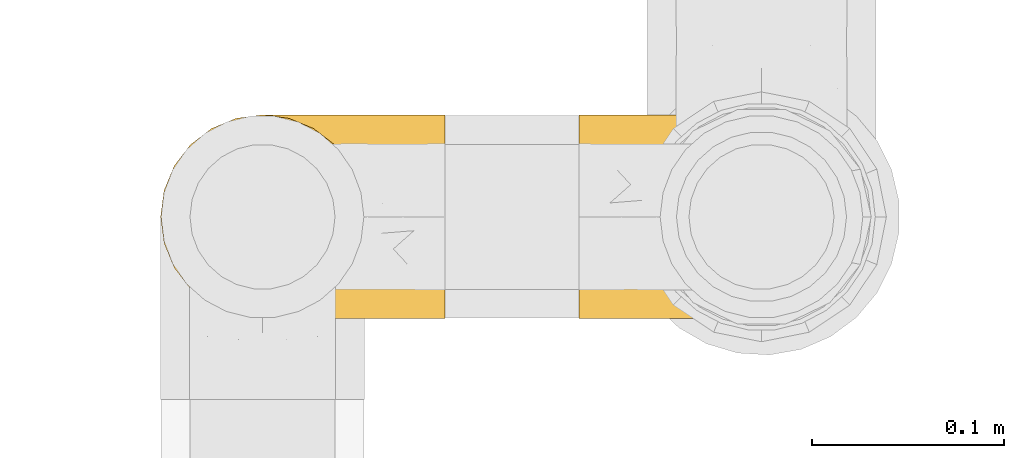
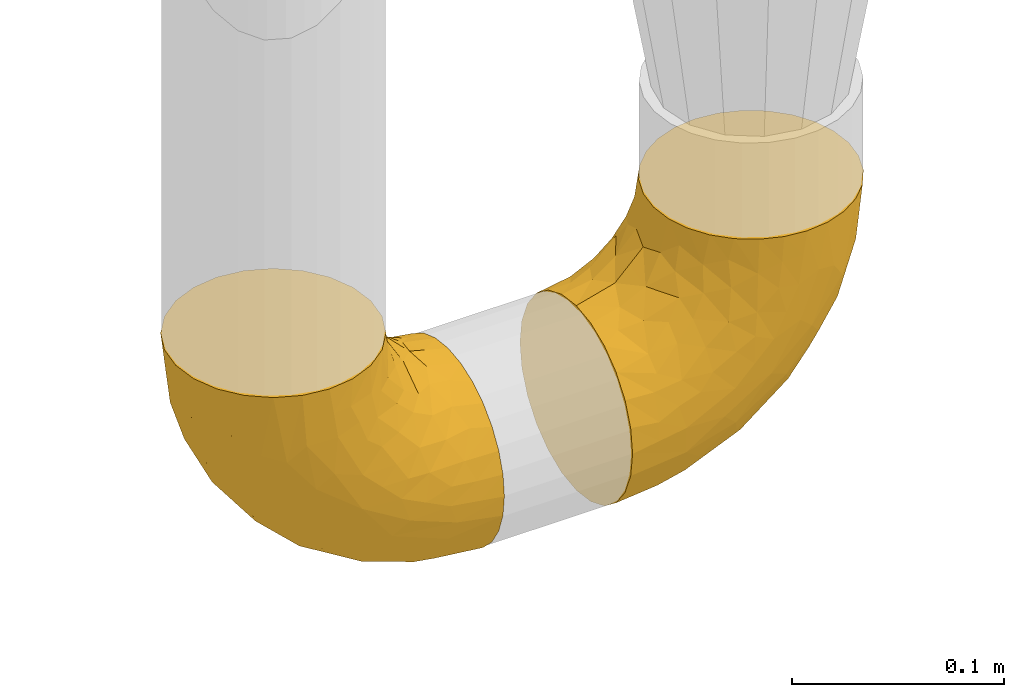
# One storey, part 476 of 827: 2 coverings.
"""IFC2X3 building model written with IfcOpenShell, lengths in millimetres."""

from ifc_helpers import new_model, entity, si_unit, converted_unit, derived_unit, direction, frame, origin, place, context, subcontext, project, spatial, faceted_brep, element, save


model = new_model("IFC2X3")

# Units and contexts
model_context = context("Model", 3, precision=0.01, world=origin(), true_north=direction((6.12303176911189e-17, 1.0)))
body_context = subcontext(model_context, "Body", "Model", "MODEL_VIEW")
ifc_project = project(units=[si_unit("LENGTHUNIT", "METRE", prefix="MILLI"), si_unit("AREAUNIT", "SQUARE_METRE"), si_unit("VOLUMEUNIT", "CUBIC_METRE"), converted_unit("PLANEANGLEUNIT", "DEGREE", entity("IfcRatioMeasure", 0.0174532925199433), si_unit("PLANEANGLEUNIT", "RADIAN"), dimensions=[0, 0, 0, 0, 0, 0, 0]), si_unit("MASSUNIT", "GRAM", prefix="KILO"), derived_unit("MASSDENSITYUNIT", [(si_unit("MASSUNIT", "GRAM", prefix="KILO"), 1), (si_unit("LENGTHUNIT", "METRE"), -3)]), derived_unit("MOMENTOFINERTIAUNIT", [(si_unit("LENGTHUNIT", "METRE"), 4)]), si_unit("TIMEUNIT", "SECOND"), si_unit("FREQUENCYUNIT", "HERTZ"), si_unit("THERMODYNAMICTEMPERATUREUNIT", "DEGREE_CELSIUS"), derived_unit("THERMALTRANSMITTANCEUNIT", [(si_unit("MASSUNIT", "GRAM", prefix="KILO"), 1), (si_unit("THERMODYNAMICTEMPERATUREUNIT", "KELVIN"), -1), (si_unit("TIMEUNIT", "SECOND"), -3)]), derived_unit("VOLUMETRICFLOWRATEUNIT", [(si_unit("LENGTHUNIT", "METRE"), 3), (si_unit("TIMEUNIT", "SECOND"), -1)]), derived_unit("MASSFLOWRATEUNIT", [(si_unit("MASSUNIT", "GRAM", prefix="KILO"), 1), (si_unit("TIMEUNIT", "SECOND"), -1)]), derived_unit("ROTATIONALFREQUENCYUNIT", [(si_unit("TIMEUNIT", "SECOND"), -1)]), si_unit("ELECTRICCURRENTUNIT", "AMPERE"), si_unit("ELECTRICVOLTAGEUNIT", "VOLT"), si_unit("POWERUNIT", "WATT"), si_unit("FORCEUNIT", "NEWTON", prefix="KILO"), si_unit("ILLUMINANCEUNIT", "LUX"), si_unit("LUMINOUSFLUXUNIT", "LUMEN"), si_unit("LUMINOUSINTENSITYUNIT", "CANDELA"), derived_unit("USERDEFINED", [(si_unit("MASSUNIT", "GRAM", prefix="KILO"), -1), (si_unit("LENGTHUNIT", "METRE"), -2), (si_unit("TIMEUNIT", "SECOND"), 3), (si_unit("LUMINOUSFLUXUNIT", "LUMEN"), 1)]), derived_unit("LINEARVELOCITYUNIT", [(si_unit("LENGTHUNIT", "METRE"), 1), (si_unit("TIMEUNIT", "SECOND"), -1)]), si_unit("PRESSUREUNIT", "PASCAL"), derived_unit("USERDEFINED", [(si_unit("LENGTHUNIT", "METRE"), -2), (si_unit("MASSUNIT", "GRAM", prefix="KILO"), 1), (si_unit("TIMEUNIT", "SECOND"), -2)]), derived_unit("LINEARFORCEUNIT", [(si_unit("MASSUNIT", "GRAM", prefix="KILO"), 1), (si_unit("LENGTHUNIT", "METRE"), 1), (si_unit("TIMEUNIT", "SECOND"), -2), (si_unit("LENGTHUNIT", "METRE"), -1)]), derived_unit("PLANARFORCEUNIT", [(si_unit("MASSUNIT", "GRAM", prefix="KILO"), 1), (si_unit("LENGTHUNIT", "METRE"), 1), (si_unit("TIMEUNIT", "SECOND"), -2), (si_unit("LENGTHUNIT", "METRE"), -2)])], contexts=[model_context])

# Site, building, storey
site_placement = place(None, origin())
site = spatial("IfcSite", under=ifc_project, at=site_placement, CompositionType="ELEMENT")
building_placement = place(site_placement, origin())
building = spatial("IfcBuilding", under=site, at=building_placement, CompositionType="ELEMENT")
storey_placement = place(building_placement, frame((0.0, 0.0, 28200.0)))
storey = spatial("IfcBuildingStorey", under=building, at=storey_placement, Name="08", CompositionType="ELEMENT", Elevation=28200.0)

# Coverings
covering_1_placement = place(storey_placement, frame((57933.24, 17445.35, 295.35)))
element("IfcCovering", 1, at=covering_1_placement, inside=storey, Name=":ADSK_", ObjectType=":ADSK_", PredefinedType="INSULATION", context=body_context, shape_type="Brep", body=[
    faceted_brep([(149.65, 42.85, 2.92), (149.65, 54.65, 1.6), (149.65, 66.46, 2.93), (149.65, 77.67, 6.85), (149.65, 87.73, 13.18), (149.65, 96.13, 21.58), (149.65, 102.45, 31.64), (149.65, 106.37, 42.85), (149.65, 107.7, 54.65), (149.65, 106.36, 66.46), (149.65, 102.44, 77.67), (149.65, 96.11, 87.73), (149.65, 87.71, 96.13), (149.65, 77.65, 102.45), (149.65, 66.44, 106.37), (149.65, 54.65, 107.7), (149.65, 42.84, 106.36), (149.65, 31.62, 102.44), (149.65, 21.56, 96.11), (149.65, 13.16, 87.71), (149.65, 6.84, 77.65), (149.65, 2.92, 66.44), (149.65, 1.6, 54.65), (149.65, 2.93, 42.84), (149.65, 6.85, 31.62), (149.65, 13.18, 21.56), (149.65, 21.58, 13.16), (149.65, 31.64, 6.84), (105.89, 68.38, 149.65), (100.59, 81.17, 149.65), (92.16, 92.16, 149.65), (81.17, 100.59, 149.65), (68.38, 105.89, 149.65), (54.65, 107.7, 149.65), (40.91, 105.89, 149.65), (28.12, 100.59, 149.65), (17.13, 92.16, 149.65), (8.7, 81.17, 149.65), (3.4, 68.38, 149.65), (1.6, 54.65, 149.65), (3.4, 40.91, 149.65), (8.7, 28.12, 149.65), (17.13, 17.13, 149.65), (28.12, 8.7, 149.65), (40.91, 3.4, 149.65), (54.65, 1.6, 149.65), (68.38, 3.4, 149.65), (81.17, 8.7, 149.65), (92.16, 17.13, 149.65), (100.59, 28.12, 149.65), (105.89, 40.91, 149.65), (107.7, 54.65, 149.65), (14.05, 23.76, 123.27), (9.45, 35.87, 114.15), (22.36, 25.52, 92.97), (4.7, 45.07, 124.11), (6.64, 54.65, 111.33), (81.47, 12.57, 42.13), (56.83, 15.93, 56.83), (64.02, 24.82, 40.31), (34.04, 37.92, 61.55), (21.43, 54.65, 75.62), (44.96, 54.65, 44.96), (49.8, 5.82, 91.12), (35.43, 8.38, 109.83), (42.1, 10.19, 88.02), (43.59, 3.86, 119.19), (57.88, 2.5, 99.11), (91.8, 19.48, 27.97), (88.01, 29.7, 21.92), (115.65, 28.0, 12.94), (18.94, 35.28, 88.29), (12.83, 45.15, 95.35), (24.96, 14.54, 113.84), (111.33, 54.65, 6.64), (113.8, 38.55, 8.58), (60.89, 40.99, 33.39), (86.24, 43.24, 17.23), (65.84, 8.56, 61.99), (124.58, 2.51, 47.9), (121.36, 5.69, 37.72), (72.79, 1.6, 93.81), (66.04, 1.6, 107.05), (59.29, 1.6, 120.29), (73.26, 3.22, 73.26), (121.69, 18.7, 18.58), (109.82, 11.86, 29.72), (40.11, 24.78, 64.31), (36.57, 15.99, 82.84), (93.81, 1.6, 72.79), (83.3, 1.6, 83.3), (136.6, 1.6, 56.71), (120.29, 1.6, 59.29), (99.11, 2.5, 57.88), (107.05, 1.6, 66.04), (91.12, 5.82, 49.8), (75.62, 54.65, 21.43), (56.97, 1.6, 134.97), (126.65, 32.3, 108.79), (116.55, 25.01, 110.84), (120.09, 18.18, 101.53), (76.06, 3.03, 111.84), (83.69, 6.69, 119.98), (71.88, 3.21, 123.54), (66.92, 2.73, 134.54), (110.43, 3.93, 80.57), (121.31, 2.55, 69.55), (81.0, 7.7, 134.56), (113.32, 54.65, 128.67), (111.09, 54.65, 136.98), (109.14, 41.58, 133.56), (95.86, 17.93, 131.66), (99.07, 14.97, 117.75), (106.92, 22.2, 118.23), (131.39, 43.45, 110.55), (136.98, 54.65, 111.09), (128.67, 54.65, 113.32), (117.07, 40.37, 120.2), (96.39, 8.47, 105.95), (106.61, 29.46, 127.69), (103.72, 32.17, 139.88), (92.14, 3.39, 92.14), (107.13, 7.76, 93.82), (98.03, 2.57, 82.28), (88.38, 11.54, 130.86), (130.66, 6.21, 78.78), (135.45, 2.9, 67.58), (123.57, 11.19, 90.58), (137.75, 14.27, 90.23), (133.2, 22.4, 99.39), (138.8, 34.87, 105.17), (120.99, 54.65, 120.99), (84.53, 4.01, 104.59), (108.72, 16.42, 108.24), (95.86, 91.36, 131.66), (130.67, 103.07, 78.8), (109.13, 67.71, 133.57), (93.81, 107.7, 72.79), (98.02, 106.72, 82.27), (110.43, 105.35, 80.59), (131.4, 65.83, 110.55), (126.66, 76.97, 108.79), (117.08, 68.91, 120.2), (108.74, 92.85, 108.25), (96.31, 100.82, 106.06), (99.11, 94.28, 117.78), (123.58, 98.08, 90.6), (107.12, 101.51, 93.87), (72.79, 107.7, 93.81), (66.04, 107.7, 107.05), (76.07, 106.25, 111.89), (56.97, 107.7, 134.97), (66.92, 106.56, 134.54), (120.29, 107.7, 59.29), (107.05, 107.7, 66.04), (121.26, 106.74, 69.56), (84.46, 105.31, 104.56), (83.69, 102.6, 119.98), (81.0, 101.59, 134.56), (71.88, 106.08, 123.54), (137.76, 95.01, 90.25), (133.21, 86.87, 99.4), (116.58, 84.27, 110.83), (120.1, 91.11, 101.52), (138.81, 74.4, 105.18), (136.6, 107.7, 56.71), (103.72, 77.12, 139.89), (106.96, 87.06, 118.22), (135.44, 106.38, 67.6), (88.38, 97.75, 130.86), (83.3, 107.7, 83.3), (92.12, 105.91, 92.12), (106.6, 79.83, 127.71), (59.29, 107.7, 120.29), (22.36, 83.77, 92.97), (14.05, 85.53, 123.27), (24.96, 94.75, 113.84), (35.43, 100.91, 109.83), (4.71, 64.22, 124.03), (9.45, 73.42, 114.15), (11.79, 64.15, 98.04), (57.88, 106.79, 99.11), (124.57, 106.79, 47.9), (121.37, 103.61, 37.74), (91.12, 103.47, 49.8), (56.83, 93.36, 56.83), (81.48, 96.75, 42.16), (64.05, 84.48, 40.3), (99.11, 106.79, 57.88), (73.26, 106.07, 73.26), (43.59, 105.43, 119.19), (19.5, 73.44, 86.61), (91.8, 89.82, 27.99), (121.7, 90.61, 18.59), (88.04, 79.61, 21.92), (123.34, 81.34, 11.28), (60.89, 68.3, 33.39), (34.04, 71.37, 61.55), (109.85, 97.44, 29.73), (42.1, 99.1, 88.01), (65.78, 100.74, 62.08), (113.81, 70.76, 8.58), (36.57, 93.3, 82.84), (40.12, 84.5, 64.3), (49.8, 103.47, 91.12), (86.08, 68.73, 18.05)], [[[0, 1, 2, 3, 4, 5, 6, 7, 8, 9, 10, 11, 12, 13, 14, 15, 16, 17, 18, 19, 20, 21, 22, 23, 24, 25, 26, 27]], [[28, 29, 30, 31, 32, 33, 34, 35, 36, 37, 38, 39, 40, 41, 42, 43, 44, 45, 46, 47, 48, 49, 50, 51]], [[52, 53, 54]], [[55, 39, 56]], [[57, 58, 59]], [[60, 61, 62]], [[63, 64, 65]], [[66, 63, 67]], [[68, 69, 70]], [[53, 71, 54]], [[41, 40, 53]], [[53, 72, 71]], [[73, 42, 52]], [[42, 41, 52]], [[74, 0, 75]], [[69, 76, 77]], [[43, 73, 64]], [[45, 44, 66]], [[57, 78, 58]], [[23, 79, 80]], [[67, 81, 82, 83]], [[67, 84, 81]], [[24, 23, 80]], [[25, 85, 26]], [[86, 85, 25]], [[42, 73, 43]], [[0, 27, 75]], [[25, 24, 86]], [[70, 26, 85]], [[0, 74, 1]], [[68, 85, 86]], [[66, 64, 63]], [[60, 59, 87]], [[54, 87, 88]], [[76, 60, 62]], [[84, 89, 90, 81]], [[79, 22, 91, 92]], [[77, 74, 75]], [[93, 92, 94, 89]], [[80, 86, 24]], [[40, 55, 53]], [[76, 59, 60]], [[93, 84, 95]], [[76, 62, 96]], [[55, 72, 53]], [[70, 27, 26]], [[75, 70, 69]], [[78, 84, 63]], [[93, 79, 92]], [[95, 86, 80]], [[77, 76, 96]], [[59, 69, 68]], [[57, 68, 86]], [[68, 57, 59]], [[59, 58, 87]], [[76, 69, 59]], [[88, 87, 58]], [[87, 54, 71]], [[86, 95, 57]], [[78, 57, 95]], [[84, 78, 95]], [[78, 63, 65]], [[58, 78, 65]], [[54, 88, 73]], [[84, 93, 89]], [[79, 95, 80]], [[79, 93, 95]], [[22, 79, 23]], [[66, 83, 97, 45]], [[84, 67, 63]], [[83, 66, 67]], [[64, 44, 43]], [[64, 66, 44]], [[65, 73, 88]], [[53, 52, 41]], [[73, 52, 54]], [[73, 65, 64]], [[65, 88, 58]], [[39, 55, 40]], [[72, 55, 56]], [[56, 61, 72]], [[60, 72, 61]], [[72, 60, 71]], [[87, 71, 60]], [[27, 70, 75]], [[68, 70, 85]], [[74, 77, 96]], [[69, 77, 75]], [[98, 99, 100]], [[46, 45, 97]], [[101, 102, 103]], [[103, 104, 83]], [[105, 94, 106]], [[107, 103, 102]], [[108, 109, 51, 110]], [[111, 112, 113]], [[114, 115, 116]], [[47, 104, 107]], [[110, 117, 108]], [[49, 48, 111]], [[102, 118, 112]], [[119, 120, 111]], [[50, 49, 120]], [[121, 122, 118]], [[105, 123, 89]], [[124, 48, 107]], [[20, 19, 125]], [[121, 81, 90]], [[117, 119, 99]], [[21, 20, 126]], [[22, 21, 91]], [[105, 125, 127]], [[110, 51, 50]], [[19, 128, 125]], [[16, 15, 115]], [[129, 98, 100]], [[126, 91, 21]], [[128, 129, 127]], [[122, 123, 105]], [[114, 117, 98]], [[17, 16, 130]], [[18, 128, 19]], [[129, 18, 17]], [[125, 106, 126]], [[115, 114, 16]], [[130, 129, 17]], [[114, 98, 130]], [[117, 116, 131, 108]], [[99, 119, 113]], [[122, 121, 123]], [[92, 126, 106]], [[105, 127, 122]], [[132, 121, 118]], [[114, 130, 16]], [[129, 130, 98]], [[50, 120, 110]], [[129, 128, 18]], [[125, 128, 127]], [[125, 126, 20]], [[91, 126, 92]], [[105, 89, 94]], [[105, 106, 125]], [[94, 92, 106]], [[100, 122, 127]], [[118, 122, 133]], [[112, 118, 133]], [[132, 118, 102]], [[132, 102, 101]], [[81, 121, 132]], [[82, 103, 83]], [[132, 101, 81]], [[104, 47, 46]], [[124, 107, 102]], [[48, 47, 107]], [[113, 112, 133]], [[112, 111, 124]], [[99, 113, 133]], [[111, 113, 119]], [[99, 133, 100]], [[117, 99, 98]], [[122, 100, 133]], [[127, 129, 100]], [[103, 82, 101]], [[81, 101, 82]], [[112, 124, 102]], [[48, 124, 111]], [[104, 103, 107]], [[46, 97, 104]], [[111, 120, 49]], [[83, 104, 97]], [[110, 120, 119]], [[117, 110, 119]], [[116, 117, 114]], [[123, 90, 89]], [[90, 123, 121]], [[30, 29, 134]], [[11, 10, 135]], [[51, 109, 108, 136]], [[137, 138, 139]], [[140, 141, 142]], [[143, 144, 145]], [[146, 139, 147]], [[148, 149, 150]], [[151, 32, 152]], [[153, 154, 155]], [[156, 150, 157]], [[158, 157, 159]], [[108, 142, 136]], [[31, 158, 152]], [[160, 161, 12]], [[162, 163, 143]], [[140, 142, 116]], [[142, 141, 162]], [[14, 164, 140]], [[14, 140, 115]], [[9, 8, 165]], [[160, 12, 11]], [[141, 164, 161]], [[13, 12, 161]], [[14, 115, 15]], [[28, 166, 29]], [[135, 139, 146]], [[141, 163, 162]], [[135, 146, 160]], [[143, 167, 162]], [[29, 166, 134]], [[116, 142, 108, 131]], [[165, 153, 168]], [[10, 9, 168]], [[168, 135, 10]], [[138, 147, 139]], [[158, 169, 157]], [[14, 13, 164]], [[116, 115, 140]], [[145, 167, 143]], [[135, 160, 11]], [[168, 153, 155]], [[138, 170, 171]], [[157, 144, 156]], [[147, 144, 143]], [[161, 164, 13]], [[140, 164, 141]], [[142, 172, 136]], [[136, 172, 166]], [[161, 160, 146]], [[165, 168, 9]], [[155, 139, 135]], [[139, 154, 137]], [[168, 155, 135]], [[139, 155, 154]], [[144, 147, 171]], [[163, 147, 143]], [[156, 144, 171]], [[157, 169, 145]], [[171, 148, 156]], [[173, 159, 149]], [[159, 157, 150]], [[152, 159, 173]], [[159, 152, 158]], [[31, 30, 158]], [[169, 30, 134]], [[157, 145, 144]], [[167, 134, 172]], [[134, 167, 145]], [[172, 142, 162]], [[162, 167, 172]], [[163, 141, 161]], [[161, 146, 163]], [[147, 163, 146]], [[148, 150, 156]], [[149, 159, 150]], [[30, 169, 158]], [[145, 169, 134]], [[151, 33, 32]], [[31, 152, 32]], [[152, 173, 151]], [[28, 51, 136]], [[134, 166, 172]], [[28, 136, 166]], [[147, 138, 171]], [[170, 138, 137]], [[170, 148, 171]], [[174, 175, 176]], [[35, 34, 177]], [[178, 179, 180]], [[181, 173, 149, 148]], [[182, 183, 184]], [[185, 186, 187]], [[188, 189, 137]], [[190, 33, 151, 173]], [[191, 179, 174]], [[34, 190, 177]], [[39, 38, 178]], [[192, 193, 194]], [[4, 3, 195]], [[175, 179, 37]], [[38, 37, 179]], [[35, 176, 36]], [[196, 62, 197]], [[181, 190, 173]], [[37, 36, 175]], [[183, 6, 198]], [[189, 148, 170, 137]], [[185, 199, 200]], [[3, 2, 201]], [[202, 185, 203]], [[8, 7, 182]], [[200, 184, 186]], [[183, 7, 6]], [[181, 189, 204]], [[200, 189, 184]], [[5, 198, 6]], [[187, 203, 185]], [[195, 3, 201]], [[205, 196, 194]], [[62, 61, 197]], [[186, 198, 192]], [[180, 179, 191]], [[2, 1, 74]], [[198, 193, 192]], [[193, 5, 4]], [[194, 193, 195]], [[2, 74, 201]], [[5, 193, 198]], [[205, 74, 96]], [[188, 137, 154, 153]], [[62, 196, 96]], [[56, 178, 180]], [[198, 184, 183]], [[184, 188, 182]], [[203, 197, 191]], [[205, 194, 201]], [[187, 192, 194]], [[192, 187, 186]], [[194, 196, 187]], [[197, 187, 196]], [[197, 203, 187]], [[202, 174, 176]], [[200, 186, 185]], [[184, 198, 186]], [[199, 185, 202]], [[189, 200, 204]], [[174, 202, 203]], [[176, 177, 199]], [[189, 181, 148]], [[190, 181, 204]], [[190, 204, 177]], [[190, 34, 33]], [[188, 153, 182]], [[189, 188, 184]], [[182, 153, 165, 8]], [[183, 182, 7]], [[199, 177, 204]], [[35, 177, 176]], [[176, 175, 36]], [[179, 175, 174]], [[200, 199, 204]], [[176, 199, 202]], [[203, 191, 174]], [[180, 197, 61]], [[197, 180, 191]], [[61, 56, 180]], [[39, 178, 56]], [[38, 179, 178]], [[194, 195, 201]], [[4, 195, 193]], [[74, 205, 201]], [[96, 196, 205]]]),
])
covering_2_placement = place(storey_placement, frame((58150.97, 17445.35, 295.35)))
element("IfcCovering", 2, at=covering_2_placement, inside=storey, Name=":ADSK_", ObjectType=":ADSK_", PredefinedType="INSULATION", context=body_context, shape_type="Brep", body=[
    faceted_brep([(148.32, 42.85, 149.65), (149.65, 54.65, 149.65), (148.31, 66.46, 149.65), (144.39, 77.67, 149.65), (138.06, 87.73, 149.65), (129.66, 96.13, 149.65), (119.6, 102.45, 149.65), (108.39, 106.37, 149.65), (96.6, 107.7, 149.65), (84.79, 106.36, 149.65), (73.57, 102.44, 149.65), (63.51, 96.11, 149.65), (55.11, 87.71, 149.65), (48.79, 77.65, 149.65), (44.87, 66.44, 149.65), (43.55, 54.65, 149.65), (44.88, 42.84, 149.65), (48.8, 31.62, 149.65), (55.13, 21.56, 149.65), (63.53, 13.16, 149.65), (73.59, 6.84, 149.65), (84.8, 2.92, 149.65), (96.6, 1.6, 149.65), (108.41, 2.93, 149.65), (119.62, 6.85, 149.65), (129.68, 13.18, 149.65), (138.08, 21.58, 149.65), (144.4, 31.64, 149.65), (1.6, 68.38, 105.89), (1.6, 81.17, 100.59), (1.6, 92.16, 92.16), (1.6, 100.59, 81.17), (1.6, 105.89, 68.38), (1.6, 107.7, 54.65), (1.6, 105.89, 40.91), (1.6, 100.59, 28.12), (1.6, 92.16, 17.13), (1.6, 81.17, 8.7), (1.6, 68.38, 3.4), (1.6, 54.65, 1.6), (1.6, 40.91, 3.4), (1.6, 28.12, 8.7), (1.6, 17.13, 17.13), (1.6, 8.7, 28.12), (1.6, 3.4, 40.91), (1.6, 1.6, 54.65), (1.6, 3.4, 68.38), (1.6, 8.7, 81.17), (1.6, 17.13, 92.16), (1.6, 28.12, 100.59), (1.6, 40.91, 105.89), (1.6, 54.65, 107.7), (27.97, 23.76, 14.05), (37.09, 35.87, 9.45), (58.27, 25.52, 22.36), (27.13, 45.07, 4.7), (39.91, 54.65, 6.64), (109.11, 12.57, 81.47), (94.41, 15.93, 56.83), (110.94, 24.82, 64.02), (89.69, 37.92, 34.04), (75.62, 54.65, 21.43), (106.28, 54.65, 44.96), (60.12, 5.82, 49.8), (41.41, 8.38, 35.43), (63.22, 10.19, 42.1), (32.05, 3.86, 43.59), (52.13, 2.5, 57.88), (123.27, 19.48, 91.8), (129.32, 29.7, 88.01), (138.3, 28.0, 115.65), (62.95, 35.28, 18.94), (55.89, 45.15, 12.83), (37.4, 14.54, 24.96), (144.6, 54.65, 111.33), (142.66, 38.55, 113.8), (117.85, 40.99, 60.89), (134.01, 43.24, 86.24), (89.25, 8.56, 65.84), (103.34, 2.51, 124.58), (113.52, 5.69, 121.36), (57.43, 1.6, 72.79), (44.19, 1.6, 66.04), (30.95, 1.6, 59.29), (77.98, 3.22, 73.26), (132.66, 18.7, 121.69), (121.52, 11.86, 109.82), (86.93, 24.78, 40.11), (68.4, 15.99, 36.57), (78.45, 1.6, 93.81), (67.94, 1.6, 83.3), (94.53, 1.6, 136.6), (91.95, 1.6, 120.29), (93.36, 2.5, 99.11), (85.2, 1.6, 107.05), (101.45, 5.82, 91.12), (129.81, 54.65, 75.62), (16.27, 1.6, 56.97), (42.46, 32.3, 126.65), (40.4, 25.01, 116.55), (49.71, 18.18, 120.09), (39.4, 3.03, 76.06), (31.26, 6.69, 83.69), (27.7, 3.21, 71.88), (16.7, 2.73, 66.92), (70.67, 3.93, 110.43), (81.69, 2.55, 121.31), (16.68, 7.7, 81.0), (22.57, 54.65, 113.32), (14.26, 54.65, 111.09), (17.68, 41.58, 109.14), (19.58, 17.93, 95.86), (33.49, 14.97, 99.07), (33.01, 22.2, 106.92), (40.69, 43.45, 131.39), (40.15, 54.65, 136.98), (37.93, 54.65, 128.67), (31.04, 40.37, 117.07), (45.29, 8.47, 96.39), (23.55, 29.46, 106.61), (11.36, 32.17, 103.72), (59.1, 3.39, 92.14), (57.42, 7.76, 107.13), (68.96, 2.57, 98.03), (20.38, 11.54, 88.38), (72.46, 6.21, 130.66), (83.66, 2.9, 135.45), (60.66, 11.19, 123.57), (61.01, 14.27, 137.75), (51.85, 22.4, 133.2), (46.07, 34.87, 138.8), (30.25, 54.65, 120.99), (46.65, 4.01, 84.53), (43.0, 16.42, 108.72), (19.58, 91.36, 95.86), (72.44, 103.07, 130.67), (17.67, 67.71, 109.13), (78.45, 107.7, 93.81), (68.97, 106.72, 98.02), (70.65, 105.35, 110.43), (40.69, 65.83, 131.4), (42.45, 76.97, 126.66), (31.04, 68.91, 117.08), (42.99, 92.85, 108.74), (45.18, 100.82, 96.31), (33.46, 94.28, 99.11), (60.64, 98.08, 123.58), (57.37, 101.51, 107.12), (57.43, 107.7, 72.79), (44.19, 107.7, 66.04), (39.35, 106.25, 76.07), (16.27, 107.7, 56.97), (16.7, 106.56, 66.92), (91.95, 107.7, 120.29), (85.2, 107.7, 107.05), (81.68, 106.74, 121.26), (46.68, 105.31, 84.46), (31.26, 102.6, 83.69), (16.68, 101.59, 81.0), (27.7, 106.08, 71.88), (60.99, 95.01, 137.76), (51.84, 86.87, 133.21), (40.41, 84.27, 116.58), (49.72, 91.11, 120.1), (46.06, 74.4, 138.81), (94.53, 107.7, 136.6), (11.35, 77.12, 103.72), (33.02, 87.06, 106.96), (83.65, 106.38, 135.44), (20.38, 97.75, 88.38), (67.94, 107.7, 83.3), (23.53, 79.83, 106.6), (59.12, 105.91, 92.12), (30.95, 107.7, 59.29), (58.27, 83.77, 22.36), (27.97, 85.53, 14.05), (37.4, 94.75, 24.96), (41.41, 100.91, 35.43), (27.21, 64.22, 4.71), (37.09, 73.42, 9.45), (53.2, 64.15, 11.79), (52.13, 106.79, 57.88), (103.34, 106.79, 124.57), (113.5, 103.61, 121.37), (101.45, 103.47, 91.12), (94.41, 93.36, 56.83), (109.08, 96.75, 81.48), (110.95, 84.48, 64.05), (93.36, 106.79, 99.11), (77.98, 106.07, 73.26), (32.05, 105.43, 43.59), (64.63, 73.44, 19.5), (123.25, 89.82, 91.8), (132.65, 90.61, 121.7), (129.32, 79.61, 88.04), (139.96, 81.34, 123.34), (117.85, 68.3, 60.89), (89.69, 71.37, 34.04), (121.51, 97.44, 109.85), (63.23, 99.1, 42.1), (89.17, 100.74, 65.78), (142.66, 70.76, 113.81), (68.4, 93.3, 36.57), (86.94, 84.5, 40.12), (60.12, 103.47, 49.8), (133.2, 68.73, 86.08)], [[[0, 1, 2, 3, 4, 5, 6, 7, 8, 9, 10, 11, 12, 13, 14, 15, 16, 17, 18, 19, 20, 21, 22, 23, 24, 25, 26, 27]], [[28, 29, 30, 31, 32, 33, 34, 35, 36, 37, 38, 39, 40, 41, 42, 43, 44, 45, 46, 47, 48, 49, 50, 51]], [[52, 53, 54]], [[55, 39, 56]], [[57, 58, 59]], [[60, 61, 62]], [[63, 64, 65]], [[66, 63, 67]], [[68, 69, 70]], [[53, 71, 54]], [[41, 40, 53]], [[53, 72, 71]], [[73, 42, 52]], [[42, 41, 52]], [[74, 0, 75]], [[69, 76, 77]], [[43, 73, 64]], [[45, 44, 66]], [[57, 78, 58]], [[23, 79, 80]], [[67, 81, 82, 83]], [[67, 84, 81]], [[24, 23, 80]], [[25, 85, 26]], [[86, 85, 25]], [[42, 73, 43]], [[0, 27, 75]], [[25, 24, 86]], [[70, 26, 85]], [[0, 74, 1]], [[68, 85, 86]], [[66, 64, 63]], [[60, 59, 87]], [[54, 87, 88]], [[76, 60, 62]], [[84, 89, 90, 81]], [[79, 22, 91, 92]], [[77, 74, 75]], [[93, 92, 94, 89]], [[80, 86, 24]], [[40, 55, 53]], [[76, 59, 60]], [[93, 84, 95]], [[76, 62, 96]], [[55, 72, 53]], [[70, 27, 26]], [[75, 70, 69]], [[78, 84, 63]], [[93, 79, 92]], [[95, 86, 80]], [[77, 76, 96]], [[59, 69, 68]], [[57, 68, 86]], [[68, 57, 59]], [[59, 58, 87]], [[76, 69, 59]], [[88, 87, 58]], [[87, 54, 71]], [[86, 95, 57]], [[78, 57, 95]], [[84, 78, 95]], [[78, 63, 65]], [[58, 78, 65]], [[54, 88, 73]], [[84, 93, 89]], [[79, 95, 80]], [[79, 93, 95]], [[22, 79, 23]], [[66, 83, 97, 45]], [[84, 67, 63]], [[83, 66, 67]], [[64, 44, 43]], [[64, 66, 44]], [[65, 73, 88]], [[53, 52, 41]], [[73, 52, 54]], [[73, 65, 64]], [[65, 88, 58]], [[39, 55, 40]], [[72, 55, 56]], [[56, 61, 72]], [[60, 72, 61]], [[72, 60, 71]], [[87, 71, 60]], [[27, 70, 75]], [[68, 70, 85]], [[74, 77, 96]], [[69, 77, 75]], [[98, 99, 100]], [[46, 45, 97]], [[101, 102, 103]], [[103, 104, 83]], [[105, 94, 106]], [[107, 103, 102]], [[108, 109, 51, 110]], [[111, 112, 113]], [[114, 115, 116]], [[47, 104, 107]], [[110, 117, 108]], [[49, 48, 111]], [[102, 118, 112]], [[119, 120, 111]], [[50, 49, 120]], [[121, 122, 118]], [[105, 123, 89]], [[124, 48, 107]], [[20, 19, 125]], [[121, 81, 90]], [[117, 119, 99]], [[21, 20, 126]], [[22, 21, 91]], [[105, 125, 127]], [[110, 51, 50]], [[19, 128, 125]], [[16, 15, 115]], [[129, 98, 100]], [[126, 91, 21]], [[128, 129, 127]], [[122, 123, 105]], [[114, 117, 98]], [[17, 16, 130]], [[18, 128, 19]], [[129, 18, 17]], [[125, 106, 126]], [[115, 114, 16]], [[130, 129, 17]], [[114, 98, 130]], [[117, 116, 131, 108]], [[99, 119, 113]], [[122, 121, 123]], [[92, 126, 106]], [[105, 127, 122]], [[132, 121, 118]], [[114, 130, 16]], [[129, 130, 98]], [[50, 120, 110]], [[129, 128, 18]], [[125, 128, 127]], [[125, 126, 20]], [[91, 126, 92]], [[105, 89, 94]], [[105, 106, 125]], [[94, 92, 106]], [[100, 122, 127]], [[118, 122, 133]], [[112, 118, 133]], [[132, 118, 102]], [[132, 102, 101]], [[81, 121, 132]], [[82, 103, 83]], [[132, 101, 81]], [[104, 47, 46]], [[124, 107, 102]], [[48, 47, 107]], [[113, 112, 133]], [[112, 111, 124]], [[99, 113, 133]], [[111, 113, 119]], [[99, 133, 100]], [[117, 99, 98]], [[122, 100, 133]], [[127, 129, 100]], [[103, 82, 101]], [[81, 101, 82]], [[112, 124, 102]], [[48, 124, 111]], [[104, 103, 107]], [[46, 97, 104]], [[111, 120, 49]], [[83, 104, 97]], [[110, 120, 119]], [[117, 110, 119]], [[116, 117, 114]], [[89, 123, 90]], [[90, 123, 121]], [[30, 29, 134]], [[11, 10, 135]], [[51, 109, 108, 136]], [[137, 138, 139]], [[140, 141, 142]], [[143, 144, 145]], [[146, 139, 147]], [[148, 149, 150]], [[151, 32, 152]], [[153, 154, 155]], [[156, 150, 157]], [[158, 157, 159]], [[108, 142, 136]], [[31, 158, 152]], [[160, 161, 12]], [[162, 163, 143]], [[140, 142, 116]], [[142, 141, 162]], [[14, 164, 140]], [[14, 140, 115]], [[9, 8, 165]], [[160, 12, 11]], [[141, 164, 161]], [[13, 12, 161]], [[14, 115, 15]], [[28, 166, 29]], [[135, 139, 146]], [[141, 163, 162]], [[135, 146, 160]], [[143, 167, 162]], [[29, 166, 134]], [[116, 142, 108, 131]], [[165, 153, 168]], [[10, 9, 168]], [[168, 135, 10]], [[138, 147, 139]], [[158, 169, 157]], [[14, 13, 164]], [[116, 115, 140]], [[145, 167, 143]], [[135, 160, 11]], [[168, 153, 155]], [[138, 137, 170]], [[157, 144, 156]], [[147, 144, 143]], [[161, 164, 13]], [[140, 164, 141]], [[142, 171, 136]], [[136, 171, 166]], [[161, 160, 146]], [[165, 168, 9]], [[155, 139, 135]], [[139, 154, 137]], [[168, 155, 135]], [[139, 155, 154]], [[144, 147, 172]], [[163, 147, 143]], [[156, 144, 172]], [[157, 169, 145]], [[172, 148, 156]], [[173, 159, 149]], [[159, 157, 150]], [[152, 159, 173]], [[159, 152, 158]], [[31, 30, 158]], [[169, 30, 134]], [[157, 145, 144]], [[167, 134, 171]], [[134, 167, 145]], [[171, 142, 162]], [[162, 167, 171]], [[163, 141, 161]], [[161, 146, 163]], [[147, 163, 146]], [[148, 150, 156]], [[149, 159, 150]], [[30, 169, 158]], [[145, 169, 134]], [[151, 33, 32]], [[31, 152, 32]], [[152, 173, 151]], [[28, 51, 136]], [[134, 166, 171]], [[28, 136, 166]], [[138, 170, 172]], [[147, 138, 172]], [[148, 172, 170]], [[174, 175, 176]], [[35, 34, 177]], [[178, 179, 180]], [[181, 173, 149, 148]], [[182, 183, 184]], [[185, 186, 187]], [[188, 189, 137]], [[190, 33, 151, 173]], [[191, 179, 174]], [[34, 190, 177]], [[39, 38, 178]], [[192, 193, 194]], [[4, 3, 195]], [[175, 179, 37]], [[38, 37, 179]], [[35, 176, 36]], [[196, 62, 197]], [[181, 190, 173]], [[37, 36, 175]], [[183, 6, 198]], [[189, 148, 170, 137]], [[185, 199, 200]], [[3, 2, 201]], [[202, 185, 203]], [[8, 7, 182]], [[200, 184, 186]], [[183, 7, 6]], [[181, 189, 204]], [[200, 189, 184]], [[5, 198, 6]], [[187, 203, 185]], [[195, 3, 201]], [[205, 196, 194]], [[62, 61, 197]], [[186, 198, 192]], [[180, 179, 191]], [[2, 1, 74]], [[198, 193, 192]], [[193, 5, 4]], [[194, 193, 195]], [[2, 74, 201]], [[5, 193, 198]], [[205, 74, 96]], [[188, 137, 154, 153]], [[62, 196, 96]], [[56, 178, 180]], [[198, 184, 183]], [[184, 188, 182]], [[203, 197, 191]], [[205, 194, 201]], [[187, 192, 194]], [[192, 187, 186]], [[194, 196, 187]], [[197, 187, 196]], [[197, 203, 187]], [[202, 174, 176]], [[200, 186, 185]], [[184, 198, 186]], [[199, 185, 202]], [[189, 200, 204]], [[174, 202, 203]], [[176, 177, 199]], [[189, 181, 148]], [[190, 181, 204]], [[190, 204, 177]], [[190, 34, 33]], [[188, 153, 182]], [[189, 188, 184]], [[182, 153, 165, 8]], [[183, 182, 7]], [[199, 177, 204]], [[35, 177, 176]], [[176, 175, 36]], [[179, 175, 174]], [[200, 199, 204]], [[176, 199, 202]], [[203, 191, 174]], [[180, 197, 61]], [[197, 180, 191]], [[61, 56, 180]], [[39, 178, 56]], [[38, 179, 178]], [[194, 195, 201]], [[4, 195, 193]], [[74, 205, 201]], [[96, 196, 205]]]),
])

save(model, "model.ifc")
